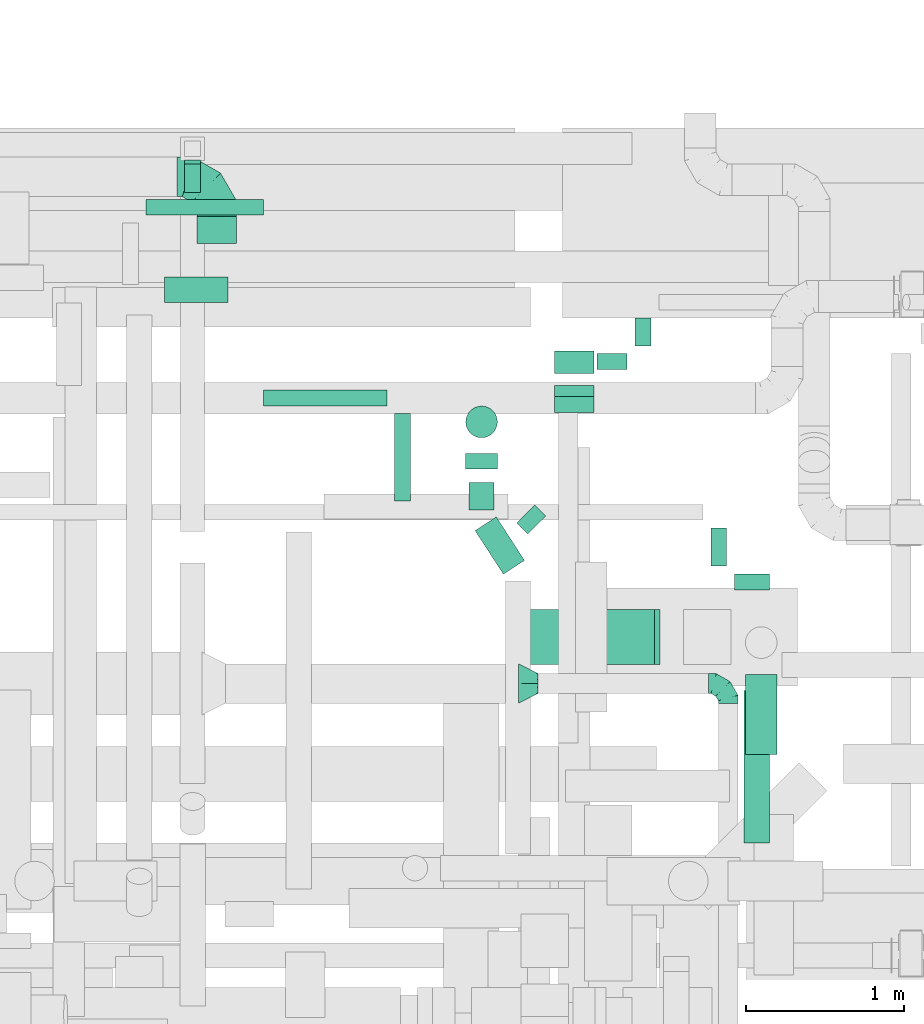
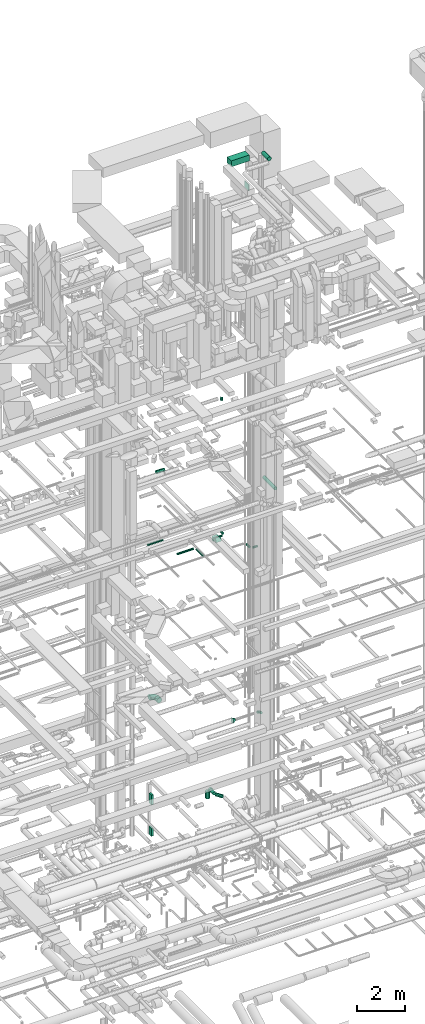
# One storey, part 291 of 337: 22 flow segments, 3 flow fittings.
"""IFC2X3 building model written with IfcOpenShell, lengths in millimetres."""

import ifcopenshell
import ifcopenshell.guid

model = None  # the IFC model being written
_history = None  # IfcOwnerHistory: only IFC2X3 demands one
_inside = {}  # id of a spatial element -> (the spatial element, [elements in it])
_under = {}  # id of a project, library or spatial element -> (it, [spatial elements below it])
_declared = {}  # id of a project -> (the project, [libraries it declares])
_typed = {}  # id of a type object -> (the type object, [elements of that type])
_made_of = {}  # id of a material, layer set ... -> (it, [elements and type objects made of it])


def new_model(schema):
    """Start an empty IFC model of exactly this schema.

    Asked for "IFC4X3", IfcOpenShell would pick the latest addendum, in which some entities
    have other attributes; the version numbers below select the first issue.
    IFC2X3 requires an IfcOwnerHistory on every rooted entity: one is made here for all.
    """
    global model, _history
    if schema == "IFC4X3":
        model = ifcopenshell.file(schema_version=(4, 3, 0, 0))
    else:
        model = ifcopenshell.file(schema=schema)
    _inside.clear()
    _under.clear()
    _declared.clear()
    _typed.clear()
    _made_of.clear()
    _history = None
    if model.schema == "IFC2X3":
        org = make("IfcOrganization", Name="unknown")
        user = make(
            "IfcPersonAndOrganization",
            ThePerson=make("IfcPerson", FamilyName="unknown"),
            TheOrganization=org,
        )
        app = make(
            "IfcApplication",
            ApplicationDeveloper=org,
            Version="unknown",
            ApplicationFullName="unknown",
            ApplicationIdentifier="unknown",
        )
        _history = make(
            "IfcOwnerHistory",
            OwningUser=user,
            OwningApplication=app,
            ChangeAction="ADDED",
            CreationDate=0,
        )
    return model


def make(cls, **values):
    """One entity of the class cls with the attributes given. An attribute that is None is left unset."""
    return model.create_entity(
        cls, **{name: value for name, value in values.items() if value is not None}
    )


def entity(cls, *values):
    """Any entity or typed value of the class cls, its attributes in the order of the schema. None: left unset."""
    e = model.create_entity(cls)
    for i, value in enumerate(values):
        if value is not None:
            e[i] = value
    return e


def rooted(cls, **values):
    """An entity with a GlobalId (a new one), such as an element, a storey or a relation."""
    return make(cls, GlobalId=ifcopenshell.guid.new(), OwnerHistory=_history, **values)


def si_unit(unit_type, name, prefix=None):
    """IfcSIUnit, for example si_unit("LENGTHUNIT", "METRE", prefix="MILLI")."""
    return make("IfcSIUnit", UnitType=unit_type, Prefix=prefix, Name=name)


def converted_unit(unit_type, name, factor, base, dimensions=None, offset=None):
    """IfcConversionBasedUnit, such as the inch: factor (a typed value) times the base unit."""
    return make(
        "IfcConversionBasedUnit"
        if offset is None
        else "IfcConversionBasedUnitWithOffset",
        ConversionOffset=offset,
        Dimensions=None
        if dimensions is None
        else entity("IfcDimensionalExponents", *dimensions),
        UnitType=unit_type,
        Name=name,
        ConversionFactor=make(
            "IfcMeasureWithUnit", ValueComponent=factor, UnitComponent=base
        ),
    )


def derived_unit(unit_type, elements):
    """IfcDerivedUnit: a product of units, each with its exponent."""
    return make(
        "IfcDerivedUnit",
        Elements=[
            make("IfcDerivedUnitElement", Unit=unit, Exponent=power)
            for unit, power in elements
        ],
        UnitType=unit_type,
    )


def assignment(units):
    """IfcUnitAssignment: the units of a project."""
    return None if units is None else make("IfcUnitAssignment", Units=units)


def point(xyz):
    """IfcCartesianPoint."""
    return None if xyz is None else make("IfcCartesianPoint", Coordinates=xyz)


def direction(xyz):
    """IfcDirection."""
    return None if xyz is None else make("IfcDirection", DirectionRatios=xyz)


def frame(location, z_axis=None, x_axis=None):
    """IfcAxis2Placement3D, a coordinate frame: its origin and axes. An axis left out is left unset."""
    return make(
        "IfcAxis2Placement3D",
        Location=point(location),
        Axis=direction(z_axis),
        RefDirection=direction(x_axis),
    )


def frame_2d(location, x_axis=None):
    """IfcAxis2Placement2D, a coordinate frame in the plane: its origin and x axis."""
    return make(
        "IfcAxis2Placement2D", Location=point(location), RefDirection=direction(x_axis)
    )


def origin():
    """The frame at (0, 0, 0) with its axes left unset."""
    return frame((0.0, 0.0, 0.0))


def origin_2d_with_axis():
    """The frame at (0, 0) in the plane with the x axis (1, 0) written out."""
    return frame_2d((0.0, 0.0), x_axis=(1.0, 0.0))


def place(relative_to, where):
    """IfcLocalPlacement: puts the frame where relative to a parent placement (None: the world)."""
    return make(
        "IfcLocalPlacement", PlacementRelTo=relative_to, RelativePlacement=where
    )


def context(
    kind, dimensions, precision=None, world=None, true_north=None, identifier=None
):
    """IfcGeometricRepresentationContext, for example the 3D "Model" context."""
    return make(
        "IfcGeometricRepresentationContext",
        ContextIdentifier=identifier,
        ContextType=kind,
        CoordinateSpaceDimension=dimensions,
        Precision=precision,
        WorldCoordinateSystem=world,
        TrueNorth=true_north,
    )


def subcontext(parent, identifier, kind, view, scale=None):
    """IfcGeometricRepresentationSubContext, for example "Body" below "Model"."""
    return make(
        "IfcGeometricRepresentationSubContext",
        ContextIdentifier=identifier,
        ContextType=kind,
        ParentContext=parent,
        TargetScale=scale,
        TargetView=view,
    )


def project(units=None, contexts=None):
    """IfcProject with its units and contexts."""
    return rooted(
        "IfcProject",
        Name="project",
        RepresentationContexts=contexts,
        UnitsInContext=assignment(units),
    )


def spatial(cls, under=None, at=None, **own):
    """A site, building, storey or space (cls), placed at a placement, below another one or the project."""
    s = rooted(cls, ObjectPlacement=at, **own)
    if under is not None:
        _under.setdefault(under.id(), (under, []))[1].append(s)
    return s


def profile(cls, at=None, kind="AREA", **sizes):
    """A parametric profile (cls). Its sizes go by their IFC names, for example OverallWidth=200.0."""
    return make(cls, ProfileType=kind, Position=at, **sizes)


def rectangle(**sizes):
    """IfcRectangleProfileDef."""
    return profile("IfcRectangleProfileDef", **sizes)


def circle(**sizes):
    """IfcCircleProfileDef."""
    return profile("IfcCircleProfileDef", **sizes)


def extrude(swept, where, along, depth):
    """IfcExtrudedAreaSolid: the profile swept, set in the frame where, extruded along a direction by depth."""
    return make(
        "IfcExtrudedAreaSolid",
        SweptArea=swept,
        Position=where,
        ExtrudedDirection=direction(along),
        Depth=depth,
    )


def faces_of(points, faces, orient=None, outer=None):
    """IfcFace entities. A face is a list of loops; a loop is a list of indices into points, from 0.

    orient and outer hold one flag for each loop. By default every Orientation is true, the
    first loop of a face is its IfcFaceOuterBound and the others are IfcFaceBound.
    """
    made = []
    for i, loops in enumerate(faces):
        bounds = []
        for j, loop in enumerate(loops):
            is_outer = j == 0 if outer is None else outer[i][j]
            bounds.append(
                make(
                    "IfcFaceOuterBound" if is_outer else "IfcFaceBound",
                    Bound=make("IfcPolyLoop", Polygon=[points[k] for k in loop]),
                    Orientation=True if orient is None else orient[i][j],
                )
            )
        made.append(make("IfcFace", Bounds=bounds))
    return made


def faceted_brep(points, faces, orient=None, outer=None, voids=None):
    """IfcFacetedBrep: a solid bounded by flat faces; with voids (closed shells), ...WithVoids."""
    shared = [point(p) for p in points]
    hull = make("IfcClosedShell", CfsFaces=faces_of(shared, faces, orient, outer))
    if voids is None:
        return make("IfcFacetedBrep", Outer=hull)
    return make(
        "IfcFacetedBrepWithVoids",
        Outer=hull,
        Voids=[
            make(cls, CfsFaces=faces_of(shared, fs, o, b)) for cls, fs, o, b in voids
        ],
    )


def shape(context_of_items, identifier, shape_type, items):
    """IfcShapeRepresentation: the items that make up one representation, for example the "Body"."""
    return make(
        "IfcShapeRepresentation",
        ContextOfItems=context_of_items,
        RepresentationIdentifier=identifier,
        RepresentationType=shape_type,
        Items=items,
    )


def source(mapping_origin, context_of_items, identifier, shape_type, items):
    """IfcRepresentationMap: a shape defined once, which mapped items show again and again."""
    return make(
        "IfcRepresentationMap",
        MappingOrigin=mapping_origin,
        MappedRepresentation=shape(context_of_items, identifier, shape_type, items),
    )


def transform(
    local_origin,
    x_axis=None,
    y_axis=None,
    z_axis=None,
    scale=None,
    scale2=None,
    scale3=None,
    uniform=True,
):
    """IfcCartesianTransformationOperator3D, or its non-uniform kind. x_axis, y_axis, z_axis: its Axis1, 2, 3."""
    if uniform:
        return make(
            "IfcCartesianTransformationOperator3D",
            Axis1=direction(x_axis),
            Axis2=direction(y_axis),
            LocalOrigin=point(local_origin),
            Scale=scale,
            Axis3=direction(z_axis),
        )
    return make(
        "IfcCartesianTransformationOperator3DnonUniform",
        Axis1=direction(x_axis),
        Axis2=direction(y_axis),
        LocalOrigin=point(local_origin),
        Scale=scale,
        Axis3=direction(z_axis),
        Scale2=scale2,
        Scale3=scale3,
    )


def mapped(mapping_source, mapping_target):
    """IfcMappedItem: shows the shape of a source again, moved by a transform."""
    return make(
        "IfcMappedItem", MappingSource=mapping_source, MappingTarget=mapping_target
    )


def material(Name=None, Category=None):
    """IfcMaterial."""
    return make("IfcMaterial", Name=Name, Category=Category)


def made_of(thing, what):
    """Note that an element or type object is made of a material, layer set ...; save() writes the relation."""
    if what is not None:
        _made_of.setdefault(what.id(), (what, []))[1].append(thing)
    return thing


def type_object(cls, material=None, **own):
    """A type object (cls), such as IfcWallType, which elements share."""
    return made_of(rooted(cls, **own), material)


def type_shapes(of_type, sources):
    """Give a type object the sources (RepresentationMaps) that its elements show as mapped items."""
    of_type.RepresentationMaps = sources


def element(
    cls,
    number,
    at=None,
    inside=None,
    cuts=None,
    type_object=None,
    material=None,
    context=None,
    identifier="Body",
    shape_type=None,
    held_by="IfcProductDefinitionShape",
    body=None,
    shapes=None,
    **own,
):
    """One element of the class cls, such as IfcWall. Its Tag is "e" and its number.

    at: its placement. inside: the storey or other place that contains it. cuts: it is an
    opening in that element (IfcRelVoidsElement). A single representation is given by context,
    identifier, shape_type and body (its items); several are given by shapes. held_by: the class
    of the entity that holds the representations. save() writes the other relations.
    """
    e = rooted(cls, Tag="e%d" % number, ObjectPlacement=at, **own)
    if body is not None:
        shapes = [shape(context, identifier, shape_type, body)]
    if shapes is not None:
        e.Representation = make(held_by, Representations=shapes)
    if inside is not None:
        _inside.setdefault(inside.id(), (inside, []))[1].append(e)
    if cuts is not None:
        rooted(
            "IfcRelVoidsElement", RelatingBuildingElement=cuts, RelatedOpeningElement=e
        )
    if type_object is not None:
        _typed.setdefault(type_object.id(), (type_object, []))[1].append(e)
    return made_of(e, material)


def aggregate(whole, parts):
    """IfcRelAggregates: a whole, such as a stair, and the parts it consists of."""
    return rooted("IfcRelAggregates", RelatingObject=whole, RelatedObjects=parts)


def save(model, path):
    """Write the relations noted so far, then the file.

    IfcRelAggregates (storeys below a building ...), IfcRelContainedInSpatialStructure (elements
    in a storey), IfcRelDefinesByType, IfcRelAssociatesMaterial and IfcRelDeclares: one each for
    every whole, place, type object, material and project.
    """
    for whole, parts in _under.values():
        aggregate(whole, parts)
    for where, things in _inside.values():
        rooted(
            "IfcRelContainedInSpatialStructure",
            RelatedElements=things,
            RelatingStructure=where,
        )
    for kind, things in _typed.values():
        rooted("IfcRelDefinesByType", RelatedObjects=things, RelatingType=kind)
    for what, things in _made_of.values():
        rooted("IfcRelAssociatesMaterial", RelatedObjects=things, RelatingMaterial=what)
    for by, libraries in _declared.values():
        rooted("IfcRelDeclares", RelatingContext=by, RelatedDefinitions=libraries)
    model.write(path)


model = new_model("IFC2X3")

# Units and contexts
model_context = context("Model", 3, precision=0.01, world=origin(), true_north=direction((6.12303176911189e-17, 1.0)))
body_context = subcontext(model_context, "Body", "Model", "MODEL_VIEW")
ifc_project = project(units=[si_unit("LENGTHUNIT", "METRE", prefix="MILLI"), si_unit("AREAUNIT", "SQUARE_METRE"), si_unit("VOLUMEUNIT", "CUBIC_METRE"), converted_unit("PLANEANGLEUNIT", "DEGREE", entity("IfcRatioMeasure", 0.0174532925199433), si_unit("PLANEANGLEUNIT", "RADIAN"), dimensions=[0, 0, 0, 0, 0, 0, 0]), si_unit("MASSUNIT", "GRAM", prefix="KILO"), derived_unit("MASSDENSITYUNIT", [(si_unit("MASSUNIT", "GRAM", prefix="KILO"), 1), (si_unit("LENGTHUNIT", "METRE"), -3)]), derived_unit("MOMENTOFINERTIAUNIT", [(si_unit("LENGTHUNIT", "METRE"), 4)]), si_unit("TIMEUNIT", "SECOND"), si_unit("FREQUENCYUNIT", "HERTZ"), si_unit("THERMODYNAMICTEMPERATUREUNIT", "DEGREE_CELSIUS"), derived_unit("THERMALTRANSMITTANCEUNIT", [(si_unit("MASSUNIT", "GRAM", prefix="KILO"), 1), (si_unit("THERMODYNAMICTEMPERATUREUNIT", "KELVIN"), -1), (si_unit("TIMEUNIT", "SECOND"), -3)]), derived_unit("VOLUMETRICFLOWRATEUNIT", [(si_unit("LENGTHUNIT", "METRE"), 3), (si_unit("TIMEUNIT", "SECOND"), -1)]), derived_unit("MASSFLOWRATEUNIT", [(si_unit("MASSUNIT", "GRAM", prefix="KILO"), 1), (si_unit("TIMEUNIT", "SECOND"), -1)]), derived_unit("ROTATIONALFREQUENCYUNIT", [(si_unit("TIMEUNIT", "SECOND"), -1)]), si_unit("ELECTRICCURRENTUNIT", "AMPERE"), si_unit("ELECTRICVOLTAGEUNIT", "VOLT"), si_unit("POWERUNIT", "WATT"), si_unit("FORCEUNIT", "NEWTON", prefix="KILO"), si_unit("ILLUMINANCEUNIT", "LUX"), si_unit("LUMINOUSFLUXUNIT", "LUMEN"), si_unit("LUMINOUSINTENSITYUNIT", "CANDELA"), derived_unit("USERDEFINED", [(si_unit("MASSUNIT", "GRAM", prefix="KILO"), -1), (si_unit("LENGTHUNIT", "METRE"), -2), (si_unit("TIMEUNIT", "SECOND"), 3), (si_unit("LUMINOUSFLUXUNIT", "LUMEN"), 1)]), derived_unit("LINEARVELOCITYUNIT", [(si_unit("LENGTHUNIT", "METRE"), 1), (si_unit("TIMEUNIT", "SECOND"), -1)]), si_unit("PRESSUREUNIT", "PASCAL"), derived_unit("USERDEFINED", [(si_unit("LENGTHUNIT", "METRE"), -2), (si_unit("MASSUNIT", "GRAM", prefix="KILO"), 1), (si_unit("TIMEUNIT", "SECOND"), -2)]), derived_unit("LINEARFORCEUNIT", [(si_unit("MASSUNIT", "GRAM", prefix="KILO"), 1), (si_unit("LENGTHUNIT", "METRE"), 1), (si_unit("TIMEUNIT", "SECOND"), -2), (si_unit("LENGTHUNIT", "METRE"), -1)]), derived_unit("PLANARFORCEUNIT", [(si_unit("MASSUNIT", "GRAM", prefix="KILO"), 1), (si_unit("LENGTHUNIT", "METRE"), 1), (si_unit("TIMEUNIT", "SECOND"), -2), (si_unit("LENGTHUNIT", "METRE"), -2)])], contexts=[model_context])

# Site, building, storey
site_placement = place(None, origin())
site = spatial("IfcSite", under=ifc_project, at=site_placement, CompositionType="ELEMENT")
building_placement = place(site_placement, origin())
building = spatial("IfcBuilding", under=site, at=building_placement, CompositionType="ELEMENT")
storey_placement = place(building_placement, origin())
storey = spatial("IfcBuildingStorey", under=building, at=storey_placement, CompositionType="ELEMENT", Elevation=0.0)

# Flow segments
duct_segment_type_1 = type_object("IfcDuctSegmentType", PredefinedType="NOTDEFINED")
flow_segment_1_placement = place(storey_placement, frame((58414.14, 19698.87, -2000.0)))
element("IfcFlowSegment", 1, at=flow_segment_1_placement, inside=storey, type_object=duct_segment_type_1, context=body_context, shape_type="SweptSolid", body=[
    extrude(rectangle(XDim=179.999999999994, YDim=100.000000000003, at=origin_2d_with_axis()), frame((50.0, 90.0, 0.0), z_axis=(0.0, 0.0, 1.0), x_axis=(0.0, -1.0, 0.0)), (0.0, 0.0, 1.0), 500.0),
])
flow_segment_2_placement = place(storey_placement, frame((58414.14, 19698.87, -3600.0)))
element("IfcFlowSegment", 2, at=flow_segment_2_placement, inside=storey, type_object=duct_segment_type_1, context=body_context, shape_type="SweptSolid", body=[
    extrude(rectangle(XDim=205.000000000001, YDim=100.000000000003, at=origin_2d_with_axis()), frame((50.0, 102.5, 0.0), z_axis=(0.0, 0.0, 1.0), x_axis=(0.0, -1.0, 0.0)), (0.0, 0.0, 1.0), 400.0),
])
flow_segment_3_placement = place(storey_placement, frame((60748.84, 18553.55, 11300.0)))
element("IfcFlowSegment", 3, at=flow_segment_3_placement, inside=storey, type_object=duct_segment_type_1, context=body_context, shape_type="SweptSolid", body=[
    extrude(rectangle(XDim=143.520257148276, YDim=250.000000000004, at=origin_2d_with_axis()), frame((125.0, 71.76, 0.0), z_axis=(0.0, 0.0, 1.0), x_axis=(0.0, -1.0, 0.0)), (0.0, 0.0, 1.0), 200.000000000002),
])
flow_segment_4_placement = place(storey_placement, frame((60748.84, 18309.77, 11346.89)))
element("IfcFlowSegment", 4, at=flow_segment_4_placement, inside=storey, type_object=duct_segment_type_1, context=body_context, shape_type="SweptSolid", body=[
    extrude(rectangle(XDim=200.000000000002, YDim=79.4228763475305, at=frame_2d((0.0, 0.0), x_axis=(0.0, 1.0))), frame((0.0, 84.39, 106.46), z_axis=(1.0, 0.0, 0.0), x_axis=(0.0, 0.866025410712591, -0.499999988000088)), (0.0, 0.0, 1.0), 249.999999999986),
])
duct_segment_type_2 = type_object("IfcDuctSegmentType", PredefinedType="NOTDEFINED")
flow_segment_5_placement = place(storey_placement, frame((60246.28, 17285.24, -931.6)))
element("IfcFlowSegment", 5, at=flow_segment_5_placement, inside=storey, type_object=duct_segment_type_2, context=body_context, shape_type="SweptSolid", body=[
    extrude(circle(Radius=80.0, at=origin_2d_with_axis()), frame((68.69, 320.17, 81.6), z_axis=(0.544639035015032, -0.838670567945421, 0.0), x_axis=(0.838670567945421, 0.544639035015032, 0.0)), (0.0, 0.0, 1.0), 327.907577426907),
])
flow_segment_6_placement = place(storey_placement, frame((60187.56, 17950.29, -951.6)))
element("IfcFlowSegment", 6, at=flow_segment_6_placement, inside=storey, type_object=duct_segment_type_2, context=body_context, shape_type="SweptSolid", body=[
    extrude(circle(Radius=100.0, at=origin_2d_with_axis()), frame((101.6, 0.0, 101.6), z_axis=(5.18928652552631e-08, 1.0, 0.0), x_axis=(1.0, -5.18928652552631e-08, 0.0)), (0.0, 0.0, 1.0), 98.4002890858727),
])
flow_segment_7_placement = place(storey_placement, frame((60207.56, 17692.56, -931.6)))
element("IfcFlowSegment", 7, at=flow_segment_7_placement, inside=storey, type_object=duct_segment_type_2, context=body_context, shape_type="SweptSolid", body=[
    extrude(circle(Radius=80.0, at=origin_2d_with_axis()), frame((81.6, 0.0, 81.6), z_axis=(0.0, 1.0, 0.0), x_axis=(1.0, 0.0, 0.0)), (0.0, 0.0, 1.0), 172.731660081321),
])
flow_segment_8_placement = place(storey_placement, frame((60187.56, 18147.09, -1400.0)))
element("IfcFlowSegment", 8, at=flow_segment_8_placement, inside=storey, type_object=duct_segment_type_2, context=body_context, shape_type="SweptSolid", body=[
    extrude(circle(Radius=100.0, at=origin_2d_with_axis()), frame((101.6, 101.6, 0.0), z_axis=(0.0, 0.0, 1.0), x_axis=(0.0, 1.0, 0.0)), (0.0, 0.0, 1.0), 350.000000000058),
])
flow_segment_9_placement = place(storey_placement, frame((58910.82, 18349.0, 11348.4)))
element("IfcFlowSegment", 9, at=flow_segment_9_placement, inside=storey, type_object=duct_segment_type_2, context=body_context, shape_type="SweptSolid", body=[
    extrude(circle(Radius=50.0, at=origin_2d_with_axis()), frame((0.0, 51.6, 51.6), z_axis=(1.0, 0.0, 0.0), x_axis=(0.0, -1.0, 0.0)), (0.0, 0.0, 1.0), 780.000000000005),
])
flow_segment_10_placement = place(storey_placement, frame((59739.22, 17748.1, 11348.4)))
element("IfcFlowSegment", 10, at=flow_segment_10_placement, inside=storey, type_object=duct_segment_type_2, context=body_context, shape_type="SweptSolid", body=[
    extrude(circle(Radius=50.0, at=origin_2d_with_axis()), frame((51.6, 0.0, 51.6), z_axis=(0.0, 1.0, 0.0), x_axis=(1.0, 0.0, 0.0)), (0.0, 0.0, 1.0), 552.494393572825),
])
flow_segment_11_placement = place(storey_placement, frame((61735.7, 17338.1, 11348.4)))
element("IfcFlowSegment", 11, at=flow_segment_11_placement, inside=storey, type_object=duct_segment_type_2, context=body_context, shape_type="SweptSolid", body=[
    extrude(circle(Radius=50.0, at=origin_2d_with_axis()), frame((51.6, 0.0, 51.6), z_axis=(0.0, 1.0, 0.0), x_axis=(-1.0, 0.0, 0.0)), (0.0, 0.0, 1.0), 240.000000000015),
])
flow_segment_12_placement = place(storey_placement, frame((61946.33, 15590.0, 15268.4)))
element("IfcFlowSegment", 12, at=flow_segment_12_placement, inside=storey, type_object=duct_segment_type_2, context=body_context, shape_type="SweptSolid", body=[
    extrude(circle(Radius=80.0, at=origin_2d_with_axis()), frame((81.6, 0.0, 81.6), z_axis=(0.0, 1.0, 0.0), x_axis=(-1.0, 0.0, 0.0)), (0.0, 0.0, 1.0), 963.554477301365),
])
flow_segment_13_placement = place(storey_placement, frame((58489.25, 19376.24, 3323.4)))
element("IfcFlowSegment", 13, at=flow_segment_13_placement, inside=storey, type_object=duct_segment_type_2, context=body_context, shape_type="SweptSolid", body=[
    extrude(circle(Radius=125.0, at=origin_2d_with_axis()), frame((126.6, 0.0, 126.6), z_axis=(0.0, 1.0, 0.0), x_axis=(-1.0, 0.0, 0.0)), (0.0, 0.0, 1.0), 170.000000000072),
])
flow_segment_14_placement = place(storey_placement, frame((61887.3, 17186.51, 11348.4)))
element("IfcFlowSegment", 14, at=flow_segment_14_placement, inside=storey, type_object=duct_segment_type_2, context=body_context, shape_type="SweptSolid", body=[
    extrude(circle(Radius=50.0, at=origin_2d_with_axis()), frame((0.0, 51.6, 51.6), z_axis=(1.0, 0.0, 0.0), x_axis=(0.0, -1.0, 0.0)), (0.0, 0.0, 1.0), 220.000000000002),
])
flow_segment_15_placement = place(storey_placement, frame((60510.8, 17539.7, 19102.97)))
element("IfcFlowSegment", 15, at=flow_segment_15_placement, inside=storey, type_object=duct_segment_type_2, context=body_context, shape_type="SweptSolid", body=[
    extrude(circle(Radius=80.0, at=origin_2d_with_axis()), frame((127.5, 58.16, 81.6), z_axis=(-0.707106781186448, 0.707106781186647, 0.0), x_axis=(-0.707106781186647, -0.707106781186448, 0.0)), (0.0, 0.0, 1.0), 98.0582617584267),
])
flow_segment_16_placement = place(storey_placement, frame((58287.28, 19001.71, 15288.4)))
element("IfcFlowSegment", 16, at=flow_segment_16_placement, inside=storey, type_object=duct_segment_type_2, context=body_context, shape_type="SweptSolid", body=[
    extrude(circle(Radius=80.0, at=origin_2d_with_axis()), frame((0.0, 81.6, 81.6), z_axis=(1.0, 0.0, 0.0), x_axis=(0.0, -1.0, 0.0)), (0.0, 0.0, 1.0), 400.000000000013),
])
flow_segment_17_placement = place(storey_placement, frame((58170.82, 19553.19, 11348.4)))
element("IfcFlowSegment", 17, at=flow_segment_17_placement, inside=storey, type_object=duct_segment_type_2, context=body_context, shape_type="SweptSolid", body=[
    extrude(circle(Radius=50.0, at=origin_2d_with_axis()), frame((0.0, 51.6, 51.6), z_axis=(1.0, 0.0, 0.0), x_axis=(0.0, 1.0, 0.0)), (0.0, 0.0, 1.0), 740.000000000048),
])
flow_segment_18_placement = place(storey_placement, frame((61257.24, 18729.55, 11348.4)))
element("IfcFlowSegment", 18, at=flow_segment_18_placement, inside=storey, type_object=duct_segment_type_2, context=body_context, shape_type="SweptSolid", body=[
    extrude(circle(Radius=50.0, at=origin_2d_with_axis()), frame((51.6, 0.0, 51.6), z_axis=(0.0, 1.0, 0.0), x_axis=(-1.0, 0.0, 0.0)), (0.0, 0.0, 1.0), 175.000000000001),
])
flow_segment_19_placement = place(storey_placement, frame((61018.84, 18577.95, 11348.4)))
element("IfcFlowSegment", 19, at=flow_segment_19_placement, inside=storey, type_object=duct_segment_type_2, context=body_context, shape_type="SweptSolid", body=[
    extrude(circle(Radius=50.0, at=origin_2d_with_axis()), frame((0.0, 51.6, 51.6), z_axis=(1.0, 0.0, 0.0), x_axis=(0.0, -1.0, 0.0)), (0.0, 0.0, 1.0), 189.999999999948),
])
flow_segment_20_placement = place(storey_placement, frame((61954.1, 16149.6, 31698.4)))
element("IfcFlowSegment", 20, at=flow_segment_20_placement, inside=storey, type_object=duct_segment_type_2, context=body_context, shape_type="SweptSolid", body=[
    extrude(circle(Radius=100.0, at=origin_2d_with_axis()), frame((101.6, 0.0, 101.6), z_axis=(0.0, 1.0, 0.0), x_axis=(1.0, 0.0, 0.0)), (0.0, 0.0, 1.0), 505.182141727195),
])
duct_segment_type_3 = type_object("IfcDuctSegmentType", PredefinedType="NOTDEFINED")
flow_segment_21_placement = place(storey_placement, frame((61381.59, 16715.46, 30062.0)))
element("IfcFlowSegment", 21, at=flow_segment_21_placement, inside=storey, type_object=duct_segment_type_3, context=body_context, shape_type="SweptSolid", body=[
    extrude(rectangle(XDim=34.4777494558797, YDim=350.000000000001, at=origin_2d_with_axis()), frame((17.24, 175.0, 0.0)), (0.0, 0.0, 1.0), 300.000000000001),
])
flow_segment_22_placement = place(storey_placement, frame((60547.93, 16715.46, 31575.0)))
element("IfcFlowSegment", 22, at=flow_segment_22_placement, inside=storey, type_object=duct_segment_type_3, context=body_context, shape_type="SweptSolid", body=[
    extrude(rectangle(XDim=868.133159999998, YDim=350.000000000001, at=origin_2d_with_axis()), frame((434.07, 175.0, 0.0)), (0.0, 0.0, 1.0), 300.000000000001),
])

# Flow fittings
ifc_material = material()
duct_fitting_type_1 = type_object("IfcDuctFittingType", PredefinedType="NOTDEFINED", material=ifc_material)
shared_shape_1 = source(origin(), body_context, "Body", "Brep", [
    faceted_brep([(-250.0, 0.0, -125.0), (-250.0, -32.35, -120.74), (-250.0, -62.5, -108.25), (-250.0, -88.39, -88.39), (-250.0, -108.25, -62.5), (-250.0, -120.74, -32.35), (-250.0, -125.0, 0.0), (-250.0, -120.74, 32.35), (-250.0, -108.25, 62.5), (-250.0, -88.39, 88.39), (-250.0, -62.5, 108.25), (-250.0, -32.35, 120.74), (-250.0, 0.0, 125.0), (-250.0, 32.35, 120.74), (-250.0, 62.5, 108.25), (-250.0, 88.39, 88.39), (-250.0, 108.25, 62.5), (-250.0, 120.74, 32.35), (-250.0, 125.0, 0.0), (-250.0, 120.74, -32.35), (-250.0, 108.25, -62.5), (-250.0, 88.39, -88.39), (-250.0, 62.5, -108.25), (-250.0, 32.35, -120.74), (-191.68, 32.35, 120.74), (-199.76, 62.5, 108.25), (-183.01, 0.0, 125.0), (-206.7, 88.39, 88.39), (-215.37, 120.74, 32.35), (-216.51, 125.0, 0.0), (-212.02, 108.25, 62.5), (-212.02, 108.25, -62.5), (-206.7, 88.39, -88.39), (-215.37, 120.74, -32.35), (-191.68, 32.35, -120.74), (-183.01, 0.0, -125.0), (-199.76, 62.5, -108.25), (-174.34, -32.35, -120.74), (-166.27, -62.5, -108.25), (-159.33, -88.39, -88.39), (-154.01, -108.25, -62.5), (-150.66, -120.74, -32.35), (-149.52, -125.0, 0.0), (-150.66, -120.74, 32.35), (-154.01, -108.25, 62.5), (-159.33, -88.39, 88.39), (-166.27, -62.5, 108.25), (-174.34, -32.35, 120.74), (-90.67, 90.67, 120.74), (-112.74, 112.74, 108.25), (-66.99, 66.99, 125.0), (-131.69, 131.69, 88.39), (-146.23, 146.23, 62.5), (-155.38, 155.38, 32.35), (-158.49, 158.49, 0.0), (-155.38, 155.38, -32.35), (-146.23, 146.23, -62.5), (-131.69, 131.69, -88.39), (-90.67, 90.67, -120.74), (-66.99, 66.99, -125.0), (-112.74, 112.74, -108.25), (-43.3, 43.3, -120.74), (-21.23, 21.23, -108.25), (-2.28, 2.28, -88.39), (12.26, -12.26, -62.5), (21.4, -21.4, -32.35), (24.52, -24.52, 0.0), (21.4, -21.4, 32.35), (12.26, -12.26, 62.5), (-2.28, 2.28, 88.39), (-21.23, 21.23, 108.25), (-43.3, 43.3, 120.74), (-32.35, 191.68, 120.74), (-62.5, 199.76, 108.25), (0.0, 183.01, 125.0), (-88.39, 206.7, 88.39), (-108.25, 212.02, 62.5), (-120.74, 215.37, 32.35), (-125.0, 216.51, 0.0), (-120.74, 215.37, -32.35), (-108.25, 212.02, -62.5), (-88.39, 206.7, -88.39), (-32.35, 191.68, -120.74), (0.0, 183.01, -125.0), (-62.5, 199.76, -108.25), (32.35, 174.34, -120.74), (62.5, 166.27, -108.25), (88.39, 159.33, -88.39), (108.25, 154.01, -62.5), (120.74, 150.66, -32.35), (125.0, 149.52, 0.0), (120.74, 150.66, 32.35), (108.25, 154.01, 62.5), (88.39, 159.33, 88.39), (62.5, 166.27, 108.25), (32.35, 174.34, 120.74), (-32.35, 250.0, -120.74), (-62.5, 250.0, -108.25), (-88.39, 250.0, -88.39), (-108.25, 250.0, -62.5), (-120.74, 250.0, -32.35), (-125.0, 250.0, 0.0), (-120.74, 250.0, 32.35), (-108.25, 250.0, 62.5), (-88.39, 250.0, 88.39), (-62.5, 250.0, 108.25), (-32.35, 250.0, 120.74), (0.0, 250.0, 125.0), (32.35, 250.0, 120.74), (62.5, 250.0, 108.25), (88.39, 250.0, 88.39), (108.25, 250.0, 62.5), (120.74, 250.0, 32.35), (125.0, 250.0, 0.0), (120.74, 250.0, -32.35), (108.25, 250.0, -62.5), (88.39, 250.0, -88.39), (62.5, 250.0, -108.25), (32.35, 250.0, -120.74), (0.0, 250.0, -125.0)], [[[0, 1, 2, 3, 4, 5, 6, 7, 8, 9, 10, 11, 12, 13, 14, 15, 16, 17, 18, 19, 20, 21, 22, 23]], [[24, 25, 14, 13]], [[26, 24, 13, 12]], [[14, 25, 27, 15]], [[28, 29, 18, 17]], [[30, 28, 17, 16]], [[15, 27, 30, 16]], [[20, 31, 32, 21]], [[33, 31, 20, 19]], [[18, 29, 33, 19]], [[34, 35, 0, 23]], [[36, 34, 23, 22]], [[21, 32, 36, 22]], [[1, 0, 35, 37]], [[2, 1, 37, 38]], [[38, 39, 3, 2]], [[5, 4, 40, 41]], [[6, 5, 41, 42]], [[39, 40, 4, 3]], [[6, 42, 43, 7]], [[7, 43, 44, 8]], [[8, 44, 45, 9]], [[9, 45, 46, 10]], [[10, 46, 47, 11]], [[26, 12, 11, 47]], [[48, 49, 25, 24]], [[50, 48, 24, 26]], [[27, 25, 49, 51]], [[52, 53, 28, 30]], [[51, 52, 30, 27]], [[29, 28, 53, 54]], [[55, 56, 31, 33]], [[54, 55, 33, 29]], [[32, 31, 56, 57]], [[58, 59, 35, 34]], [[60, 58, 34, 36]], [[57, 60, 36, 32]], [[37, 35, 59, 61]], [[38, 37, 61, 62]], [[39, 38, 62, 63]], [[41, 40, 64, 65]], [[42, 41, 65, 66]], [[63, 64, 40, 39]], [[43, 42, 66, 67]], [[44, 43, 67, 68]], [[68, 69, 45, 44]], [[46, 45, 69, 70]], [[47, 46, 70, 71]], [[26, 47, 71, 50]], [[72, 73, 49, 48]], [[74, 72, 48, 50]], [[51, 49, 73, 75]], [[76, 77, 53, 52]], [[75, 76, 52, 51]], [[54, 53, 77, 78]], [[79, 80, 56, 55]], [[78, 79, 55, 54]], [[57, 56, 80, 81]], [[82, 83, 59, 58]], [[84, 82, 58, 60]], [[81, 84, 60, 57]], [[61, 59, 83, 85]], [[62, 61, 85, 86]], [[63, 62, 86, 87]], [[65, 64, 88, 89]], [[66, 65, 89, 90]], [[87, 88, 64, 63]], [[67, 66, 90, 91]], [[68, 67, 91, 92]], [[92, 93, 69, 68]], [[70, 69, 93, 94]], [[71, 70, 94, 95]], [[50, 71, 95, 74]], [[96, 97, 98, 99, 100, 101, 102, 103, 104, 105, 106, 107, 108, 109, 110, 111, 112, 113, 114, 115, 116, 117, 118, 119]], [[72, 74, 107, 106]], [[73, 72, 106, 105]], [[75, 73, 105, 104]], [[77, 76, 103, 102]], [[78, 77, 102, 101]], [[75, 104, 103, 76]], [[78, 101, 100, 79]], [[79, 100, 99, 80]], [[80, 99, 98, 81]], [[84, 97, 96, 82]], [[82, 96, 119, 83]], [[84, 81, 98, 97]], [[83, 119, 118, 85]], [[85, 118, 117, 86]], [[116, 87, 86, 117]], [[88, 115, 114, 89]], [[89, 114, 113, 90]], [[115, 88, 87, 116]], [[91, 90, 113, 112]], [[92, 91, 112, 111]], [[111, 110, 93, 92]], [[95, 94, 109, 108]], [[74, 95, 108, 107]], [[110, 109, 94, 93]]]),
])
type_shapes(duct_fitting_type_1, [shared_shape_1])
flow_fitting_1_placement = place(storey_placement, frame((58615.84, 19796.24, 3450.0), z_axis=(0.0, 0.0, 1.0), x_axis=(0.0, 1.0, 0.0)))
element("IfcFlowFitting", 23, at=flow_fitting_1_placement, inside=storey, type_object=duct_fitting_type_1, material=ifc_material, context=body_context, shape_type="MappedRepresentation", body=[
    mapped(shared_shape_1, transform((0.0, 0.0, 0.0), scale=1.0)),
])
duct_fitting_type_2 = type_object("IfcDuctFittingType", PredefinedType="NOTDEFINED", material=ifc_material)
shared_shape_2 = source(origin(), body_context, "Body", "Brep", [
    faceted_brep([(-125.0, 0.0, -62.5), (-125.0, -16.18, -60.37), (-125.0, -31.25, -54.13), (-125.0, -44.19, -44.19), (-125.0, -54.13, -31.25), (-125.0, -60.37, -16.18), (-125.0, -62.5, 0.0), (-125.0, -60.37, 16.18), (-125.0, -54.13, 31.25), (-125.0, -44.19, 44.19), (-125.0, -31.25, 54.13), (-125.0, -16.18, 60.37), (-125.0, 0.0, 62.5), (-125.0, 16.18, 60.37), (-125.0, 31.25, 54.13), (-125.0, 44.19, 44.19), (-125.0, 54.13, 31.25), (-125.0, 60.37, 16.18), (-125.0, 62.5, 0.0), (-125.0, 60.37, -16.18), (-125.0, 54.13, -31.25), (-125.0, 44.19, -44.19), (-125.0, 31.25, -54.13), (-125.0, 16.18, -60.37), (-95.84, 16.18, 60.37), (-99.88, 31.25, 54.13), (-91.51, 0.0, 62.5), (-103.35, 44.19, 44.19), (-107.68, 60.37, 16.18), (-108.25, 62.5, 0.0), (-106.01, 54.13, 31.25), (-106.01, 54.13, -31.25), (-103.35, 44.19, -44.19), (-107.68, 60.37, -16.18), (-95.84, 16.18, -60.37), (-91.51, 0.0, -62.5), (-99.88, 31.25, -54.13), (-87.17, -16.18, -60.37), (-83.13, -31.25, -54.13), (-79.66, -44.19, -44.19), (-77.0, -54.13, -31.25), (-75.33, -60.37, -16.18), (-74.76, -62.5, 0.0), (-75.33, -60.37, 16.18), (-77.0, -54.13, 31.25), (-79.66, -44.19, 44.19), (-83.13, -31.25, 54.13), (-87.17, -16.18, 60.37), (-45.34, 45.34, 60.37), (-56.37, 56.37, 54.13), (-33.49, 33.49, 62.5), (-65.85, 65.85, 44.19), (-73.12, 73.12, 31.25), (-77.69, 77.69, 16.18), (-79.25, 79.25, 0.0), (-77.69, 77.69, -16.18), (-73.12, 73.12, -31.25), (-65.85, 65.85, -44.19), (-45.34, 45.34, -60.37), (-33.49, 33.49, -62.5), (-56.37, 56.37, -54.13), (-21.65, 21.65, -60.37), (-10.62, 10.62, -54.13), (-1.14, 1.14, -44.19), (6.13, -6.13, -31.25), (10.7, -10.7, -16.18), (12.26, -12.26, 0.0), (10.7, -10.7, 16.18), (6.13, -6.13, 31.25), (-1.14, 1.14, 44.19), (-10.62, 10.62, 54.13), (-21.65, 21.65, 60.37), (-16.18, 95.84, 60.37), (-31.25, 99.88, 54.13), (0.0, 91.51, 62.5), (-44.19, 103.35, 44.19), (-54.13, 106.01, 31.25), (-60.37, 107.68, 16.18), (-62.5, 108.25, 0.0), (-60.37, 107.68, -16.18), (-54.13, 106.01, -31.25), (-44.19, 103.35, -44.19), (-16.18, 95.84, -60.37), (0.0, 91.51, -62.5), (-31.25, 99.88, -54.13), (16.18, 87.17, -60.37), (31.25, 83.13, -54.13), (44.19, 79.66, -44.19), (54.13, 77.0, -31.25), (60.37, 75.33, -16.18), (62.5, 74.76, 0.0), (60.37, 75.33, 16.18), (54.13, 77.0, 31.25), (44.19, 79.66, 44.19), (31.25, 83.13, 54.13), (16.18, 87.17, 60.37), (-16.18, 125.0, -60.37), (-31.25, 125.0, -54.13), (-44.19, 125.0, -44.19), (-54.13, 125.0, -31.25), (-60.37, 125.0, -16.18), (-62.5, 125.0, 0.0), (-60.37, 125.0, 16.18), (-54.13, 125.0, 31.25), (-44.19, 125.0, 44.19), (-31.25, 125.0, 54.13), (-16.18, 125.0, 60.37), (0.0, 125.0, 62.5), (16.18, 125.0, 60.37), (31.25, 125.0, 54.13), (44.19, 125.0, 44.19), (54.13, 125.0, 31.25), (60.37, 125.0, 16.18), (62.5, 125.0, 0.0), (60.37, 125.0, -16.18), (54.13, 125.0, -31.25), (44.19, 125.0, -44.19), (31.25, 125.0, -54.13), (16.18, 125.0, -60.37), (0.0, 125.0, -62.5)], [[[0, 1, 2, 3, 4, 5, 6, 7, 8, 9, 10, 11, 12, 13, 14, 15, 16, 17, 18, 19, 20, 21, 22, 23]], [[24, 25, 14, 13]], [[26, 24, 13, 12]], [[14, 25, 27, 15]], [[28, 29, 18, 17]], [[30, 28, 17, 16]], [[15, 27, 30, 16]], [[20, 31, 32, 21]], [[33, 31, 20, 19]], [[18, 29, 33, 19]], [[34, 35, 0, 23]], [[36, 34, 23, 22]], [[21, 32, 36, 22]], [[1, 0, 35, 37]], [[2, 1, 37, 38]], [[38, 39, 3, 2]], [[5, 4, 40, 41]], [[6, 5, 41, 42]], [[39, 40, 4, 3]], [[6, 42, 43, 7]], [[7, 43, 44, 8]], [[45, 9, 8, 44]], [[9, 45, 46, 10]], [[10, 46, 47, 11]], [[26, 12, 11, 47]], [[48, 49, 25, 24]], [[50, 48, 24, 26]], [[27, 25, 49, 51]], [[52, 53, 28, 30]], [[51, 52, 30, 27]], [[29, 28, 53, 54]], [[55, 56, 31, 33]], [[54, 55, 33, 29]], [[57, 32, 31, 56]], [[58, 59, 35, 34]], [[60, 58, 34, 36]], [[57, 60, 36, 32]], [[37, 35, 59, 61]], [[38, 37, 61, 62]], [[39, 38, 62, 63]], [[41, 40, 64, 65]], [[42, 41, 65, 66]], [[63, 64, 40, 39]], [[43, 42, 66, 67]], [[44, 43, 67, 68]], [[68, 69, 45, 44]], [[46, 45, 69, 70]], [[47, 46, 70, 71]], [[26, 47, 71, 50]], [[72, 73, 49, 48]], [[74, 72, 48, 50]], [[51, 49, 73, 75]], [[76, 77, 53, 52]], [[75, 76, 52, 51]], [[54, 53, 77, 78]], [[79, 80, 56, 55]], [[78, 79, 55, 54]], [[81, 57, 56, 80]], [[82, 83, 59, 58]], [[84, 82, 58, 60]], [[81, 84, 60, 57]], [[61, 59, 83, 85]], [[62, 61, 85, 86]], [[63, 62, 86, 87]], [[65, 64, 88, 89]], [[66, 65, 89, 90]], [[87, 88, 64, 63]], [[67, 66, 90, 91]], [[68, 67, 91, 92]], [[92, 93, 69, 68]], [[70, 69, 93, 94]], [[71, 70, 94, 95]], [[50, 71, 95, 74]], [[96, 97, 98, 99, 100, 101, 102, 103, 104, 105, 106, 107, 108, 109, 110, 111, 112, 113, 114, 115, 116, 117, 118, 119]], [[72, 74, 107, 106]], [[73, 72, 106, 105]], [[75, 73, 105, 104]], [[77, 76, 103, 102]], [[78, 77, 102, 101]], [[75, 104, 103, 76]], [[78, 101, 100, 79]], [[79, 100, 99, 80]], [[80, 99, 98, 81]], [[96, 119, 83, 82]], [[97, 96, 82, 84]], [[84, 81, 98, 97]], [[83, 119, 118, 85]], [[85, 118, 117, 86]], [[116, 87, 86, 117]], [[88, 115, 114, 89]], [[89, 114, 113, 90]], [[115, 88, 87, 116]], [[91, 90, 113, 112]], [[92, 91, 112, 111]], [[111, 110, 93, 92]], [[95, 94, 109, 108]], [[74, 95, 108, 107]], [[110, 109, 94, 93]]]),
])
type_shapes(duct_fitting_type_2, [shared_shape_2])
flow_fitting_2_placement = place(storey_placement, frame((61847.05, 16596.24, 3450.0), z_axis=(0.0, 0.0, 1.0), x_axis=(0.0, 1.0, 0.0)))
element("IfcFlowFitting", 24, at=flow_fitting_2_placement, inside=storey, type_object=duct_fitting_type_2, material=ifc_material, context=body_context, shape_type="MappedRepresentation", body=[
    mapped(shared_shape_2, transform((0.0, 0.0, 0.0), scale=1.0)),
])
duct_fitting_type_3 = type_object("IfcDuctFittingType", PredefinedType="NOTDEFINED", material=ifc_material)
shared_shape_3 = source(origin(), body_context, "Body", "Brep", [
    faceted_brep([(125.0, -57.74, 23.92), (125.0, -60.12, 11.96), (125.0, -62.5, 0.0), (125.0, -60.12, -11.96), (125.0, -57.74, -23.92), (125.0, -50.97, -34.06), (125.0, -44.19, -44.19), (125.0, -34.06, -50.97), (125.0, -23.92, -57.74), (125.0, -11.96, -60.12), (125.0, 0.0, -62.5), (125.0, 11.96, -60.12), (125.0, 23.92, -57.74), (125.0, 34.06, -50.97), (125.0, 44.19, -44.19), (125.0, 50.97, -34.06), (125.0, 57.74, -23.92), (125.0, 60.12, -11.96), (125.0, 62.5, 0.0), (125.0, 60.12, 11.96), (125.0, 57.74, 23.92), (125.0, 50.97, 34.06), (125.0, 44.19, 44.19), (125.0, 34.06, 50.97), (125.0, 23.92, 57.74), (125.0, 11.96, 60.12), (125.0, 0.0, 62.5), (125.0, -11.96, 60.12), (125.0, -23.92, 57.74), (125.0, -34.06, 50.97), (125.0, -44.19, 44.19), (125.0, -50.97, 34.06), (0.0, -125.0, 0.0), (0.0, -118.88, 38.63), (0.0, -101.13, 73.47), (0.0, -73.47, 101.13), (0.0, -38.63, 118.88), (0.0, 0.0, 125.0), (0.0, 38.63, 118.88), (0.0, 73.47, 101.13), (0.0, 101.13, 73.47), (0.0, 118.88, 38.63), (0.0, 125.0, 0.0), (0.0, 118.88, -38.63), (0.0, 101.13, -73.47), (0.0, 73.47, -101.13), (0.0, 38.63, -118.88), (0.0, 0.0, -125.0), (0.0, -38.63, -118.88), (0.0, -73.47, -101.13), (0.0, -101.13, -73.47), (0.0, -118.88, -38.63)], [[[0, 1, 2, 3, 4, 5, 6, 7, 8, 9, 10, 11, 12, 13, 14, 15, 16, 17, 18, 19, 20, 21, 22, 23, 24, 25, 26, 27, 28, 29, 30, 31]], [[32, 33, 34, 35, 36, 37, 38, 39, 40, 41, 42, 43, 44, 45, 46, 47, 48, 49, 50, 51]], [[37, 25, 38]], [[24, 39, 38]], [[40, 22, 21, 20]], [[41, 20, 19]], [[39, 24, 23, 22]], [[18, 42, 19]], [[25, 37, 26]], [[40, 20, 41]], [[19, 42, 41]], [[25, 24, 38]], [[22, 40, 39]], [[32, 1, 33]], [[0, 34, 33]], [[35, 30, 29, 28]], [[36, 28, 27]], [[34, 0, 31, 30]], [[26, 37, 27]], [[1, 32, 2]], [[35, 28, 36]], [[27, 37, 36]], [[1, 0, 33]], [[30, 35, 34]], [[47, 9, 48]], [[8, 49, 48]], [[50, 6, 5, 4]], [[51, 4, 3]], [[49, 8, 7, 6]], [[2, 32, 3]], [[9, 47, 10]], [[50, 4, 51]], [[3, 32, 51]], [[9, 8, 48]], [[6, 50, 49]], [[42, 17, 43]], [[16, 44, 43]], [[45, 14, 13, 12]], [[46, 12, 11]], [[44, 16, 15, 14]], [[10, 47, 11]], [[17, 42, 18]], [[45, 12, 46]], [[11, 47, 46]], [[17, 16, 43]], [[14, 45, 44]]]),
])
type_shapes(duct_fitting_type_3, [shared_shape_3])
flow_fitting_3_placement = place(storey_placement, frame((60522.05, 16596.24, 3450.0)))
element("IfcFlowFitting", 25, at=flow_fitting_3_placement, inside=storey, type_object=duct_fitting_type_3, material=ifc_material, context=body_context, shape_type="MappedRepresentation", body=[
    mapped(shared_shape_3, transform((0.0, 0.0, 0.0), scale=1.0)),
])

save(model, "model.ifc")
